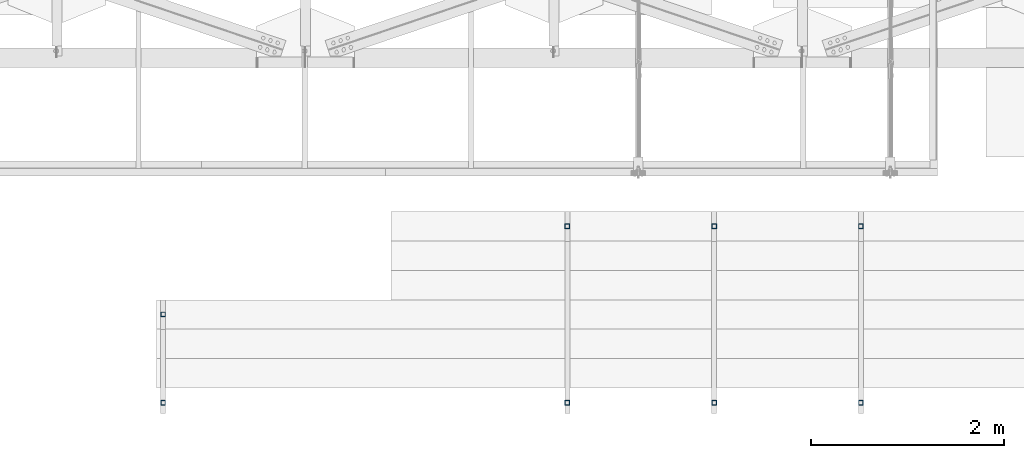
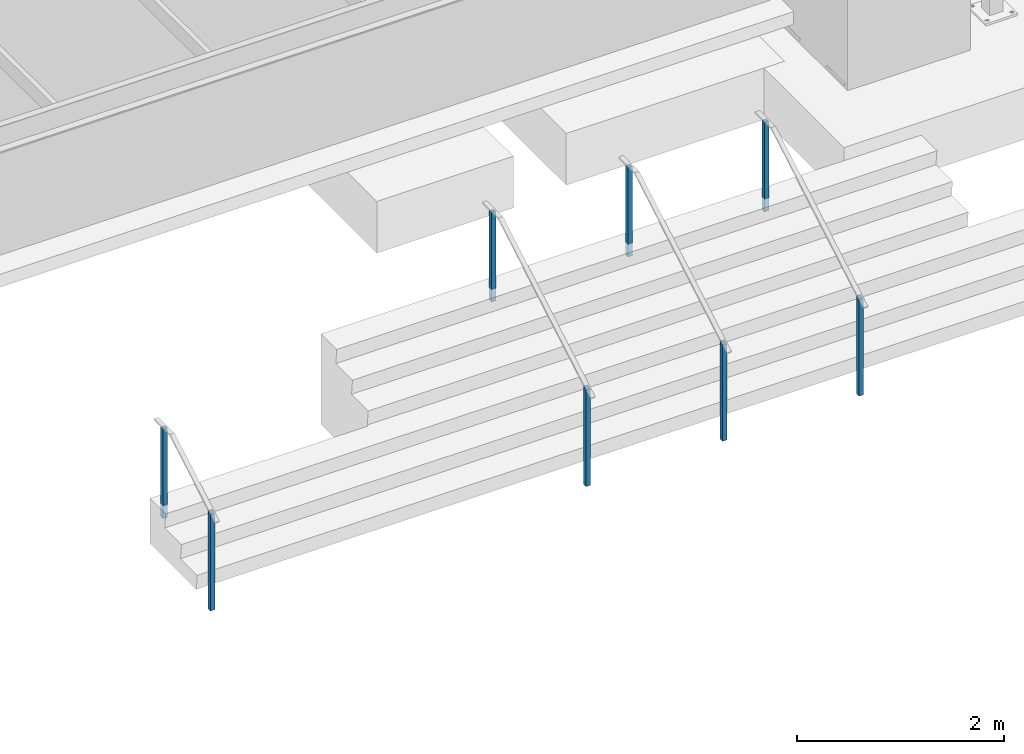
# One storey, part 892 of 1763: 8 columns, 4 elements without a shape of their own.
"""IFC2X3 building model written with IfcOpenShell, lengths in millimetres."""

from ifc_helpers import new_model, si_unit, frame, origin_with_axes, place, context, subcontext, project, spatial, faceted_brep, material, type_object, element, aggregate, save


model = new_model("IFC2X3")

# Units and contexts
model_context = context("Model", 3, precision=1e-05, world=origin_with_axes())
body_context = subcontext(model_context, "Body", "Model", "MODEL_VIEW")
ifc_project = project(units=[si_unit("LENGTHUNIT", "METRE", prefix="MILLI"), si_unit("AREAUNIT", "SQUARE_METRE"), si_unit("VOLUMEUNIT", "CUBIC_METRE"), si_unit("MASSUNIT", "GRAM", prefix="KILO"), si_unit("TIMEUNIT", "SECOND"), si_unit("PLANEANGLEUNIT", "RADIAN"), si_unit("SOLIDANGLEUNIT", "STERADIAN"), si_unit("THERMODYNAMICTEMPERATUREUNIT", "DEGREE_CELSIUS"), si_unit("LUMINOUSINTENSITYUNIT", "LUMEN")], contexts=[model_context])

# Site, building, storey
site_placement = place(None, origin_with_axes())
site = spatial("IfcSite", under=ifc_project, at=site_placement, CompositionType="ELEMENT")
building_placement = place(site_placement, origin_with_axes())
building = spatial("IfcBuilding", under=site, at=building_placement, Name="Undefined", CompositionType="ELEMENT")
storey_placement = place(building_placement, origin_with_axes())
storey = spatial("IfcBuildingStorey", under=building, at=storey_placement, Name="Undefined", CompositionType="ELEMENT", Elevation=0.0)

# Assembly, columns
assembly_1_placement = place(storey_placement, origin_with_axes())
assembly_1 = element("IfcElementAssembly", 1, at=assembly_1_placement, inside=storey, Name="HANDRAIL", AssemblyPlace="NOTDEFINED", PredefinedType="RIGID_FRAME")
ifc_material = material()
column_type = type_object("IfcColumnType", Name="2X2X3/16 SQUARE TUBE SS", PredefinedType="NOTDEFINED")
column_1_placement = place(assembly_1_placement, frame((-52755.2372736984, -19034.1249941662, 4114.8), z_axis=(-1.0, 0.0, 0.0), x_axis=(0.0, 0.0, 1.0)))
column_1 = element("IfcColumn", 2, at=column_1_placement, type_object=column_type, material=ifc_material, Name="POST TUBE", ObjectType="2X2X3/16 SQUARE TUBE SS", context=body_context, shape_type="Brep", body=[
    faceted_brep([(0.0, 20.6375000000007, -20.6374999999971), (0.0, -20.6375000000007, -20.6374999999971), (1132.63432765349, -20.6375000000007, -20.6374999999971), (1156.71140979222, 20.6375000000007, -20.6374999999971), (0.0, -20.6375000000007, 20.6374999999971), (1132.63432765349, -20.6375000000007, 20.6374999999971), (0.0, 20.6375000000007, 20.6374999999971), (1156.71140979222, 20.6375000000007, 20.6374999999971), (-1.45519152283669e-11, 25.4000000000015, -25.3999999999869), (1.45519152283669e-11, 25.4000000000015, 25.3999999999796), (1159.48953465438, 25.4000000000015, 25.4000000000015), (1159.48953465438, 25.4000000000015, -25.4000000000015), (0.0, -25.4000000000015, 25.3999999999942), (1129.85620279133, -25.4000000000015, 25.4000000000015), (-1.45519152283669e-11, -25.4000000000015, -25.3999999999869), (1129.85620279133, -25.4000000000015, -25.4000000000015)], [[[0, 1, 2, 3]], [[1, 4, 5, 2]], [[4, 6, 7, 5]], [[6, 0, 3, 7]], [[8, 9, 10, 11]], [[9, 12, 13, 10]], [[12, 14, 15, 13]], [[14, 8, 11, 15]], [[13, 15, 11, 10], [5, 7, 3, 2]], [[14, 12, 9, 8], [6, 4, 1, 0]]]),
])
column_2_placement = place(assembly_1_placement, frame((-52755.2372736984, -17205.3250002697, 5181.6), z_axis=(-1.0, 0.0, 0.0), x_axis=(0.0, 0.0, 1.0)))
column_2 = element("IfcColumn", 3, at=column_2_placement, type_object=column_type, material=ifc_material, Name="POST TUBE", ObjectType="2X2X3/16 SQUARE TUBE SS", context=body_context, shape_type="Brep", body=[
    faceted_brep([(-1.45519152283669e-11, -25.4000000000015, -25.3999999999869), (-1.45519152283669e-11, 25.4000000000015, -25.3999999999869), (1057.27498047955, 25.4000000000015, -25.4000000000015), (1057.27498047955, -25.4000000000015, -25.4000000000015), (0.0, -25.4000000000015, 25.3999999999942), (1057.27498047955, -25.4000000000015, 25.4000000000015), (1.45519152283669e-11, 25.4000000000015, 25.3999999999796), (1057.27498047955, 25.4000000000015, 25.4000000000015), (0.0, 20.6375000000007, 20.6374999999971), (0.0, -20.6375000000007, 20.6374999999971), (0.0, -20.6375000000007, -20.6374999999971), (0.0, 20.6375000000007, -20.6374999999971), (1057.27498047955, -20.6375000000007, 20.6374999999971), (1057.27498047955, -20.6375000000007, -20.6374999999971), (1057.27498047955, 20.6375000000007, -20.6374999999971), (1057.27498047955, 20.6375000000007, 20.6374999999971)], [[[0, 1, 2, 3]], [[4, 0, 3, 5]], [[6, 4, 5, 7]], [[1, 6, 7, 2]], [[0, 4, 6, 1], [8, 9, 10, 11]], [[10, 9, 12, 13]], [[11, 10, 13, 14]], [[8, 11, 14, 15]], [[9, 8, 15, 12]], [[2, 7, 5, 3], [14, 13, 12, 15]]]),
])
aggregate(assembly_1, [column_1, column_2])

assembly_2_placement = place(storey_placement, origin_with_axes())
assembly_2 = element("IfcElementAssembly", 4, at=assembly_2_placement, inside=storey, Name="HANDRAIL", AssemblyPlace="NOTDEFINED", PredefinedType="RIGID_FRAME")
column_3_placement = place(assembly_2_placement, frame((-49707.2372736984, -19034.1249941662, 4114.8), z_axis=(-1.0, 0.0, 0.0), x_axis=(0.0, 0.0, 1.0)))
column_3 = element("IfcColumn", 5, at=column_3_placement, type_object=column_type, material=ifc_material, Name="POST TUBE", ObjectType="2X2X3/16 SQUARE TUBE SS", context=body_context, shape_type="Brep", body=[
    faceted_brep([(0.0, 20.6375000000007, -20.6374999999971), (0.0, -20.6375000000007, -20.6374999999971), (1132.63432765349, -20.6375000000007, -20.6374999999971), (1156.71140979222, 20.6375000000007, -20.6374999999971), (0.0, -20.6375000000007, 20.6374999999971), (1132.63432765349, -20.6375000000007, 20.6374999999971), (0.0, 20.6375000000007, 20.6374999999971), (1156.71140979222, 20.6375000000007, 20.6374999999971), (-1.45519152283669e-11, 25.4000000000015, -25.3999999999869), (1.45519152283669e-11, 25.4000000000015, 25.3999999999796), (1159.48953465438, 25.4000000000015, 25.4000000000015), (1159.48953465438, 25.4000000000015, -25.4000000000015), (0.0, -25.4000000000015, 25.3999999999942), (1129.85620279133, -25.4000000000015, 25.4000000000015), (-1.45519152283669e-11, -25.4000000000015, -25.3999999999869), (1129.85620279133, -25.4000000000015, -25.4000000000015)], [[[0, 1, 2, 3]], [[1, 4, 5, 2]], [[4, 6, 7, 5]], [[6, 0, 3, 7]], [[8, 9, 10, 11]], [[9, 12, 13, 10]], [[12, 14, 15, 13]], [[14, 8, 11, 15]], [[13, 15, 11, 10], [5, 7, 3, 2]], [[14, 12, 9, 8], [6, 4, 1, 0]]]),
])
column_4_placement = place(assembly_2_placement, frame((-49707.2372736984, -17205.3250002697, 5181.6), z_axis=(-1.0, 0.0, 0.0), x_axis=(0.0, 0.0, 1.0)))
column_4 = element("IfcColumn", 6, at=column_4_placement, type_object=column_type, material=ifc_material, Name="POST TUBE", ObjectType="2X2X3/16 SQUARE TUBE SS", context=body_context, shape_type="Brep", body=[
    faceted_brep([(-1.45519152283669e-11, -25.4000000000015, -25.3999999999869), (-1.45519152283669e-11, 25.4000000000015, -25.3999999999869), (1057.27498047955, 25.4000000000015, -25.4000000000015), (1057.27498047955, -25.4000000000015, -25.4000000000015), (0.0, -25.4000000000015, 25.3999999999942), (1057.27498047955, -25.4000000000015, 25.4000000000015), (1.45519152283669e-11, 25.4000000000015, 25.3999999999796), (1057.27498047955, 25.4000000000015, 25.4000000000015), (0.0, 20.6375000000007, 20.6374999999971), (0.0, -20.6375000000007, 20.6374999999971), (0.0, -20.6375000000007, -20.6374999999971), (0.0, 20.6375000000007, -20.6374999999971), (1057.27498047955, -20.6375000000007, 20.6374999999971), (1057.27498047955, -20.6375000000007, -20.6374999999971), (1057.27498047955, 20.6375000000007, -20.6374999999971), (1057.27498047955, 20.6375000000007, 20.6374999999971)], [[[0, 1, 2, 3]], [[4, 0, 3, 5]], [[6, 4, 5, 7]], [[1, 6, 7, 2]], [[0, 4, 6, 1], [8, 9, 10, 11]], [[10, 9, 12, 13]], [[11, 10, 13, 14]], [[8, 11, 14, 15]], [[9, 8, 15, 12]], [[2, 7, 5, 3], [14, 13, 12, 15]]]),
])
aggregate(assembly_2, [column_3, column_4])

assembly_3_placement = place(storey_placement, origin_with_axes())
assembly_3 = element("IfcElementAssembly", 7, at=assembly_3_placement, inside=storey, Name="HANDRAIL", AssemblyPlace="NOTDEFINED", PredefinedType="RIGID_FRAME")
column_5_placement = place(assembly_3_placement, frame((-51231.2372736984, -19034.1249941662, 4114.8), z_axis=(-1.0, 0.0, 0.0), x_axis=(0.0, 0.0, 1.0)))
column_5 = element("IfcColumn", 8, at=column_5_placement, type_object=column_type, material=ifc_material, Name="POST TUBE", ObjectType="2X2X3/16 SQUARE TUBE SS", context=body_context, shape_type="Brep", body=[
    faceted_brep([(0.0, 20.6375000000007, -20.6374999999971), (0.0, -20.6375000000007, -20.6374999999971), (1132.63432765349, -20.6375000000007, -20.6374999999971), (1156.71140979222, 20.6375000000007, -20.6374999999971), (0.0, -20.6375000000007, 20.6374999999971), (1132.63432765349, -20.6375000000007, 20.6374999999971), (0.0, 20.6375000000007, 20.6374999999971), (1156.71140979222, 20.6375000000007, 20.6374999999971), (-1.45519152283669e-11, 25.4000000000015, -25.3999999999869), (1.45519152283669e-11, 25.4000000000015, 25.3999999999796), (1159.48953465438, 25.4000000000015, 25.4000000000015), (1159.48953465438, 25.4000000000015, -25.4000000000015), (0.0, -25.4000000000015, 25.3999999999942), (1129.85620279133, -25.4000000000015, 25.4000000000015), (-1.45519152283669e-11, -25.4000000000015, -25.3999999999869), (1129.85620279133, -25.4000000000015, -25.4000000000015)], [[[0, 1, 2, 3]], [[1, 4, 5, 2]], [[4, 6, 7, 5]], [[6, 0, 3, 7]], [[8, 9, 10, 11]], [[9, 12, 13, 10]], [[12, 14, 15, 13]], [[14, 8, 11, 15]], [[13, 15, 11, 10], [5, 7, 3, 2]], [[14, 12, 9, 8], [6, 4, 1, 0]]]),
])
column_6_placement = place(assembly_3_placement, frame((-51231.2372736984, -17205.3250002697, 5181.6), z_axis=(-1.0, 0.0, 0.0), x_axis=(0.0, 0.0, 1.0)))
column_6 = element("IfcColumn", 9, at=column_6_placement, type_object=column_type, material=ifc_material, Name="POST TUBE", ObjectType="2X2X3/16 SQUARE TUBE SS", context=body_context, shape_type="Brep", body=[
    faceted_brep([(-1.45519152283669e-11, -25.4000000000015, -25.3999999999869), (-1.45519152283669e-11, 25.4000000000015, -25.3999999999869), (1057.27498047955, 25.4000000000015, -25.4000000000015), (1057.27498047955, -25.4000000000015, -25.4000000000015), (0.0, -25.4000000000015, 25.3999999999942), (1057.27498047955, -25.4000000000015, 25.4000000000015), (1.45519152283669e-11, 25.4000000000015, 25.3999999999796), (1057.27498047955, 25.4000000000015, 25.4000000000015), (0.0, 20.6375000000007, 20.6374999999971), (0.0, -20.6375000000007, 20.6374999999971), (0.0, -20.6375000000007, -20.6374999999971), (0.0, 20.6375000000007, -20.6374999999971), (1057.27498047955, -20.6375000000007, 20.6374999999971), (1057.27498047955, -20.6375000000007, -20.6374999999971), (1057.27498047955, 20.6375000000007, -20.6374999999971), (1057.27498047955, 20.6375000000007, 20.6374999999971)], [[[0, 1, 2, 3]], [[4, 0, 3, 5]], [[6, 4, 5, 7]], [[1, 6, 7, 2]], [[0, 4, 6, 1], [8, 9, 10, 11]], [[10, 9, 12, 13]], [[11, 10, 13, 14]], [[8, 11, 14, 15]], [[9, 8, 15, 12]], [[2, 7, 5, 3], [14, 13, 12, 15]]]),
])
aggregate(assembly_3, [column_5, column_6])

assembly_4_placement = place(storey_placement, origin_with_axes())
assembly_4 = element("IfcElementAssembly", 10, at=assembly_4_placement, inside=storey, Name="HANDRAIL", AssemblyPlace="NOTDEFINED", PredefinedType="RIGID_FRAME")
column_7_placement = place(assembly_4_placement, frame((-56952.5872736984, -19034.1249628451, 4114.8), z_axis=(-1.0, 0.0, 0.0), x_axis=(0.0, 0.0, 1.0)))
column_7 = element("IfcColumn", 11, at=column_7_placement, type_object=column_type, material=ifc_material, Name="POST TUBE", ObjectType="2X2X3/16 SQUARE TUBE SS", context=body_context, shape_type="Brep", body=[
    faceted_brep([(0.0, 20.6375000000007, -20.6374999999971), (0.0, -20.6375000000007, -20.6374999999971), (1132.63432765349, -20.6375000000007, -20.6374999999971), (1156.71140979222, 20.6375000000007, -20.6374999999971), (0.0, -20.6375000000007, 20.6374999999971), (1132.63432765349, -20.6375000000007, 20.6374999999971), (0.0, 20.6375000000007, 20.6374999999971), (1156.71140979222, 20.6375000000007, 20.6374999999971), (-1.45519152283669e-11, 25.4000000000015, -25.3999999999869), (1.45519152283669e-11, 25.4000000000015, 25.3999999999796), (1159.48953465438, 25.4000000000015, 25.4000000000015), (1159.48953465438, 25.4000000000015, -25.4000000000015), (0.0, -25.4000000000015, 25.3999999999942), (1129.85620279133, -25.4000000000015, 25.4000000000015), (-1.45519152283669e-11, -25.4000000000015, -25.3999999999869), (1129.85620279133, -25.4000000000015, -25.4000000000015)], [[[0, 1, 2, 3]], [[1, 4, 5, 2]], [[4, 6, 7, 5]], [[6, 0, 3, 7]], [[8, 9, 10, 11]], [[9, 12, 13, 10]], [[12, 14, 15, 13]], [[14, 8, 11, 15]], [[13, 15, 11, 10], [5, 7, 3, 2]], [[14, 12, 9, 8], [6, 4, 1, 0]]]),
])
column_8_placement = place(assembly_4_placement, frame((-56952.5872736984, -18119.7249628451, 4648.19997558594), z_axis=(-1.0, 0.0, 0.0), x_axis=(0.0, 0.0, 1.0)))
column_8 = element("IfcColumn", 12, at=column_8_placement, type_object=column_type, material=ifc_material, Name="POST TUBE", ObjectType="2X2X3/16 SQUARE TUBE SS", context=body_context, shape_type="Brep", body=[
    faceted_brep([(-1.45519152283669e-11, -25.4000000000015, -25.3999999999869), (-1.45519152283669e-11, 25.4000000000015, -25.3999999999869), (1057.27498047955, 25.4000000000015, -25.4000000000015), (1057.27498047955, -25.4000000000015, -25.4000000000015), (0.0, -25.4000000000015, 25.3999999999942), (1057.27498047955, -25.4000000000015, 25.4000000000015), (1.45519152283669e-11, 25.4000000000015, 25.3999999999796), (1057.27498047955, 25.4000000000015, 25.4000000000015), (0.0, 20.6375000000007, 20.6374999999971), (0.0, -20.6375000000007, 20.6374999999971), (0.0, -20.6375000000007, -20.6374999999971), (0.0, 20.6375000000007, -20.6374999999971), (1057.27498047955, -20.6375000000007, 20.6374999999971), (1057.27498047955, -20.6375000000007, -20.6374999999971), (1057.27498047955, 20.6375000000007, -20.6374999999971), (1057.27498047955, 20.6375000000007, 20.6374999999971)], [[[0, 1, 2, 3]], [[4, 0, 3, 5]], [[6, 4, 5, 7]], [[1, 6, 7, 2]], [[0, 4, 6, 1], [8, 9, 10, 11]], [[10, 9, 12, 13]], [[11, 10, 13, 14]], [[8, 11, 14, 15]], [[9, 8, 15, 12]], [[2, 7, 5, 3], [14, 13, 12, 15]]]),
])
aggregate(assembly_4, [column_7, column_8])

save(model, "model.ifc")
